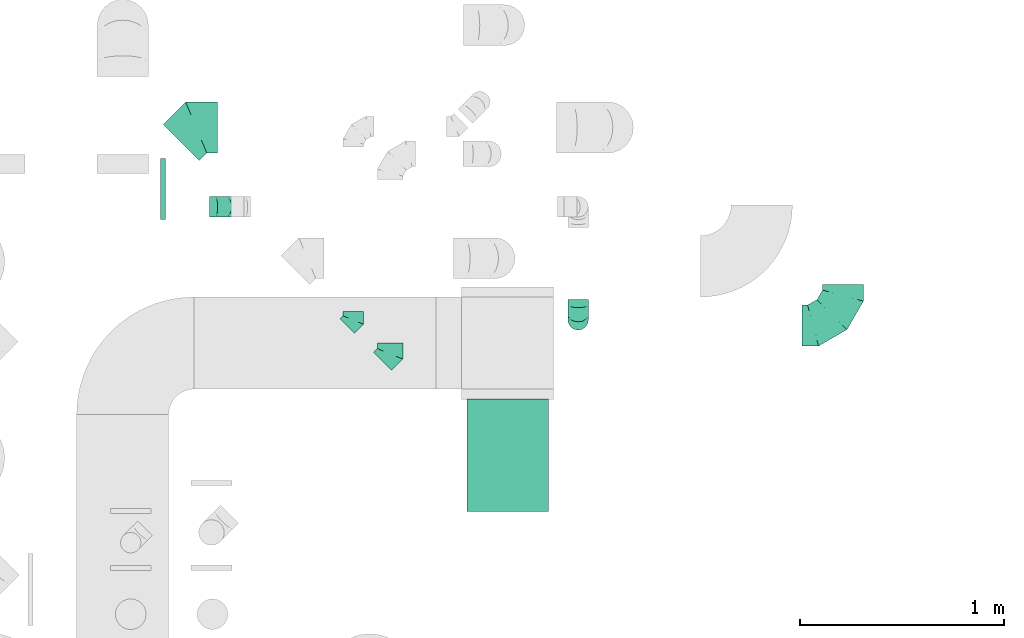
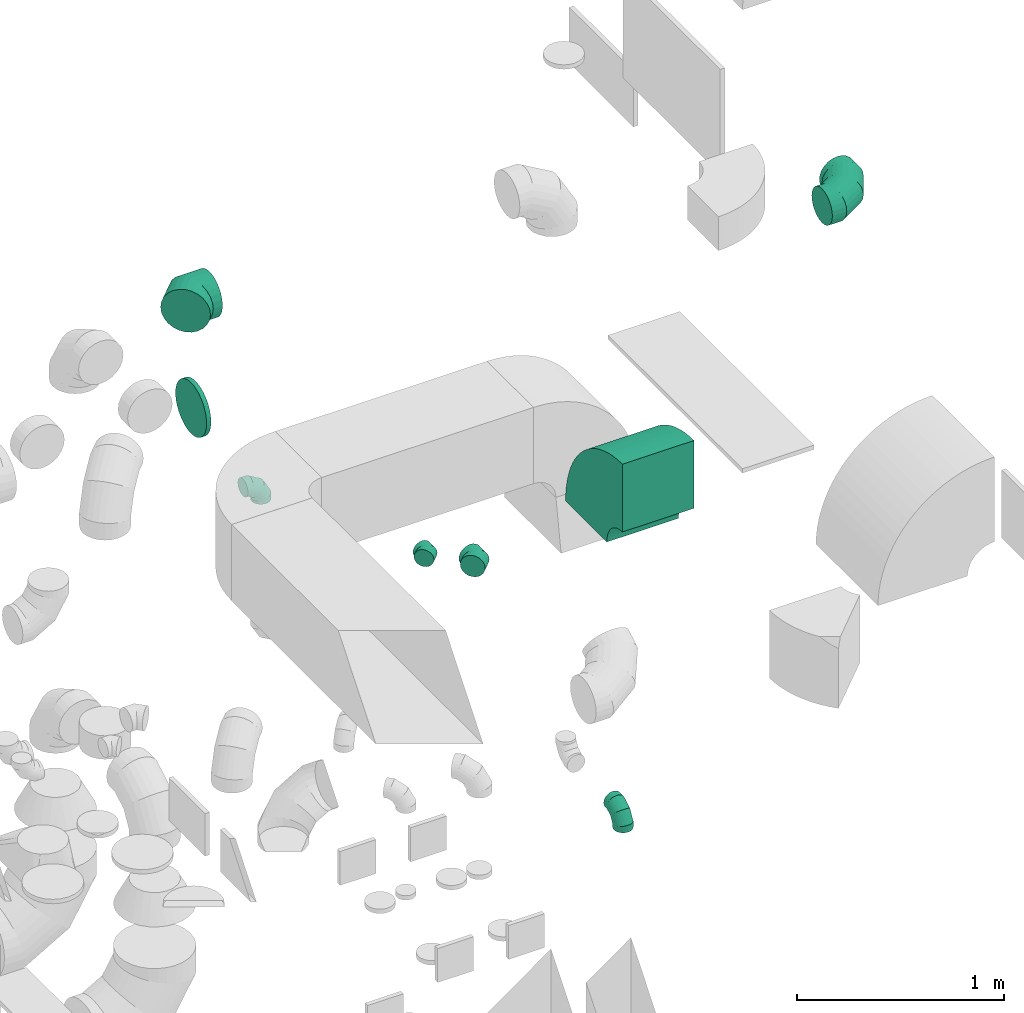
# One storey, part 37 of 59: 8 flow fittings.
"""IFC2X3 building model written with IfcOpenShell, lengths in millimetres."""

from ifc_helpers import new_model, entity, si_unit, converted_unit, derived_unit, direction, frame, frame_2d, origin, origin_2d_with_axis, place, context, subcontext, project, spatial, polyline, circle_curve, parameter, trimmed, segment, composite_curve, circle, outline, extrude, faceted_brep, source, transform, mapped, material, type_object, type_shapes, element, save


model = new_model("IFC2X3")

# Units and contexts
model_context = context("Model", 3, precision=0.01, world=origin(), true_north=direction((6.12303176911189e-17, 1.0)))
body_context = subcontext(model_context, "Body", "Model", "MODEL_VIEW")
ifc_project = project(units=[si_unit("LENGTHUNIT", "METRE", prefix="MILLI"), si_unit("AREAUNIT", "SQUARE_METRE"), si_unit("VOLUMEUNIT", "CUBIC_METRE"), converted_unit("PLANEANGLEUNIT", "DEGREE", entity("IfcRatioMeasure", 0.0174532925199433), si_unit("PLANEANGLEUNIT", "RADIAN"), dimensions=[0, 0, 0, 0, 0, 0, 0]), si_unit("MASSUNIT", "GRAM", prefix="KILO"), derived_unit("MASSDENSITYUNIT", [(si_unit("MASSUNIT", "GRAM", prefix="KILO"), 1), (si_unit("LENGTHUNIT", "METRE"), -3)]), derived_unit("MOMENTOFINERTIAUNIT", [(si_unit("LENGTHUNIT", "METRE"), 4)]), si_unit("TIMEUNIT", "SECOND"), si_unit("FREQUENCYUNIT", "HERTZ"), si_unit("THERMODYNAMICTEMPERATUREUNIT", "DEGREE_CELSIUS"), derived_unit("THERMALTRANSMITTANCEUNIT", [(si_unit("MASSUNIT", "GRAM", prefix="KILO"), 1), (si_unit("THERMODYNAMICTEMPERATUREUNIT", "KELVIN"), -1), (si_unit("TIMEUNIT", "SECOND"), -3)]), derived_unit("VOLUMETRICFLOWRATEUNIT", [(si_unit("LENGTHUNIT", "METRE"), 3), (si_unit("TIMEUNIT", "SECOND"), -1)]), derived_unit("MASSFLOWRATEUNIT", [(si_unit("MASSUNIT", "GRAM", prefix="KILO"), 1), (si_unit("TIMEUNIT", "SECOND"), -1)]), derived_unit("ROTATIONALFREQUENCYUNIT", [(si_unit("TIMEUNIT", "SECOND"), -1)]), si_unit("ELECTRICCURRENTUNIT", "AMPERE"), si_unit("ELECTRICVOLTAGEUNIT", "VOLT"), si_unit("POWERUNIT", "WATT"), si_unit("FORCEUNIT", "NEWTON", prefix="KILO"), si_unit("ILLUMINANCEUNIT", "LUX"), si_unit("LUMINOUSFLUXUNIT", "LUMEN"), si_unit("LUMINOUSINTENSITYUNIT", "CANDELA"), derived_unit("USERDEFINED", [(si_unit("MASSUNIT", "GRAM", prefix="KILO"), -1), (si_unit("LENGTHUNIT", "METRE"), -2), (si_unit("TIMEUNIT", "SECOND"), 3), (si_unit("LUMINOUSFLUXUNIT", "LUMEN"), 1)]), derived_unit("LINEARVELOCITYUNIT", [(si_unit("LENGTHUNIT", "METRE"), 1), (si_unit("TIMEUNIT", "SECOND"), -1)]), si_unit("PRESSUREUNIT", "PASCAL"), derived_unit("USERDEFINED", [(si_unit("LENGTHUNIT", "METRE"), -2), (si_unit("MASSUNIT", "GRAM", prefix="KILO"), 1), (si_unit("TIMEUNIT", "SECOND"), -2)]), derived_unit("LINEARFORCEUNIT", [(si_unit("MASSUNIT", "GRAM", prefix="KILO"), 1), (si_unit("LENGTHUNIT", "METRE"), 1), (si_unit("TIMEUNIT", "SECOND"), -2), (si_unit("LENGTHUNIT", "METRE"), -1)]), derived_unit("PLANARFORCEUNIT", [(si_unit("MASSUNIT", "GRAM", prefix="KILO"), 1), (si_unit("LENGTHUNIT", "METRE"), 1), (si_unit("TIMEUNIT", "SECOND"), -2), (si_unit("LENGTHUNIT", "METRE"), -2)])], contexts=[model_context])

# Site, building, storey
site_placement = place(None, origin())
site = spatial("IfcSite", under=ifc_project, at=site_placement, CompositionType="ELEMENT")
building_placement = place(site_placement, origin())
building = spatial("IfcBuilding", under=site, at=building_placement, CompositionType="ELEMENT")
storey_placement = place(building_placement, frame((0.0, 0.0, 28200.0)))
storey = spatial("IfcBuildingStorey", under=building, at=storey_placement, CompositionType="ELEMENT", Elevation=28200.0)

# Flow fittings
ifc_material = material()
duct_fitting_type_1 = type_object("IfcDuctFittingType", PredefinedType="NOTDEFINED", material=ifc_material)
shared_shape_1 = source(origin(), body_context, "Body", "SweptSolid", [
    extrude(circle(Radius=149.999999999999, at=origin_2d_with_axis()), frame((0.0, 0.0, 0.0), z_axis=(1.0, 0.0, 0.0), x_axis=(0.0, 1.0, 0.0)), (0.0, 0.0, 1.0), 25.0000000000018),
])
type_shapes(duct_fitting_type_1, [shared_shape_1])
flow_fitting_1_placement = place(storey_placement, frame((57282.5, 12192.32, 3100.0)))
element("IfcFlowFitting", 1, at=flow_fitting_1_placement, inside=storey, type_object=duct_fitting_type_1, material=ifc_material, context=body_context, shape_type="MappedRepresentation", body=[
    mapped(shared_shape_1, transform((0.0, 0.0, 0.0), scale=1.0)),
])
duct_fitting_type_2 = type_object("IfcDuctFittingType", PredefinedType="NOTDEFINED", material=ifc_material)
shared_shape_2 = source(origin(), body_context, "Body", "Brep", [
    faceted_brep([(-100.0, 0.0, -50.0), (-100.0, -12.94, -48.3), (-100.0, -25.0, -43.3), (-100.0, -35.36, -35.36), (-100.0, -43.3, -25.0), (-100.0, -48.3, -12.94), (-100.0, -50.0, 0.0), (-100.0, -48.3, 12.94), (-100.0, -43.3, 25.0), (-100.0, -35.36, 35.36), (-100.0, -25.0, 43.3), (-100.0, -12.94, 48.3), (-100.0, 0.0, 50.0), (-100.0, 12.94, 48.3), (-100.0, 25.0, 43.3), (-100.0, 35.36, 35.36), (-100.0, 43.3, 25.0), (-100.0, 48.3, 12.94), (-100.0, 50.0, 0.0), (-100.0, 48.3, -12.94), (-100.0, 43.3, -25.0), (-100.0, 35.36, -35.36), (-100.0, 25.0, -43.3), (-100.0, 12.94, -48.3), (-76.67, 12.94, 48.3), (-79.9, 25.0, 43.3), (-73.21, 0.0, 50.0), (-82.68, 35.36, 35.36), (-86.15, 48.3, 12.94), (-86.6, 50.0, 0.0), (-84.81, 43.3, 25.0), (-84.81, 43.3, -25.0), (-82.68, 35.36, -35.36), (-86.15, 48.3, -12.94), (-76.67, 12.94, -48.3), (-73.21, 0.0, -50.0), (-79.9, 25.0, -43.3), (-69.74, -12.94, -48.3), (-66.51, -25.0, -43.3), (-63.73, -35.36, -35.36), (-61.6, -43.3, -25.0), (-60.26, -48.3, -12.94), (-59.81, -50.0, 0.0), (-60.26, -48.3, 12.94), (-61.6, -43.3, 25.0), (-63.73, -35.36, 35.36), (-66.51, -25.0, 43.3), (-69.74, -12.94, 48.3), (-36.27, 36.27, 48.3), (-45.1, 45.1, 43.3), (-26.79, 26.79, 50.0), (-52.68, 52.68, 35.36), (-58.49, 58.49, 25.0), (-62.15, 62.15, 12.94), (-63.4, 63.4, 0.0), (-62.15, 62.15, -12.94), (-58.49, 58.49, -25.0), (-52.68, 52.68, -35.36), (-36.27, 36.27, -48.3), (-26.79, 26.79, -50.0), (-45.1, 45.1, -43.3), (-17.32, 17.32, -48.3), (-8.49, 8.49, -43.3), (-0.91, 0.91, -35.36), (4.9, -4.9, -25.0), (8.56, -8.56, -12.94), (9.81, -9.81, 0.0), (8.56, -8.56, 12.94), (4.9, -4.9, 25.0), (-0.91, 0.91, 35.36), (-8.49, 8.49, 43.3), (-17.32, 17.32, 48.3), (-12.94, 76.67, 48.3), (-25.0, 79.9, 43.3), (0.0, 73.21, 50.0), (-35.36, 82.68, 35.36), (-43.3, 84.81, 25.0), (-48.3, 86.15, 12.94), (-50.0, 86.6, 0.0), (-48.3, 86.15, -12.94), (-43.3, 84.81, -25.0), (-35.36, 82.68, -35.36), (-12.94, 76.67, -48.3), (0.0, 73.21, -50.0), (-25.0, 79.9, -43.3), (12.94, 69.74, -48.3), (25.0, 66.51, -43.3), (35.36, 63.73, -35.36), (43.3, 61.6, -25.0), (48.3, 60.26, -12.94), (50.0, 59.81, 0.0), (48.3, 60.26, 12.94), (43.3, 61.6, 25.0), (35.36, 63.73, 35.36), (25.0, 66.51, 43.3), (12.94, 69.74, 48.3), (-12.94, 100.0, -48.3), (-25.0, 100.0, -43.3), (-35.36, 100.0, -35.36), (-43.3, 100.0, -25.0), (-48.3, 100.0, -12.94), (-50.0, 100.0, 0.0), (-48.3, 100.0, 12.94), (-43.3, 100.0, 25.0), (-35.36, 100.0, 35.36), (-25.0, 100.0, 43.3), (-12.94, 100.0, 48.3), (0.0, 100.0, 50.0), (12.94, 100.0, 48.3), (25.0, 100.0, 43.3), (35.36, 100.0, 35.36), (43.3, 100.0, 25.0), (48.3, 100.0, 12.94), (50.0, 100.0, 0.0), (48.3, 100.0, -12.94), (43.3, 100.0, -25.0), (35.36, 100.0, -35.36), (25.0, 100.0, -43.3), (12.94, 100.0, -48.3), (0.0, 100.0, -50.0)], [[[0, 1, 2, 3, 4, 5, 6, 7, 8, 9, 10, 11, 12, 13, 14, 15, 16, 17, 18, 19, 20, 21, 22, 23]], [[24, 25, 14, 13]], [[26, 24, 13, 12]], [[14, 25, 27, 15]], [[28, 29, 18, 17]], [[30, 28, 17, 16]], [[15, 27, 30, 16]], [[20, 31, 32, 21]], [[33, 31, 20, 19]], [[18, 29, 33, 19]], [[34, 35, 0, 23]], [[36, 34, 23, 22]], [[32, 36, 22, 21]], [[2, 1, 37, 38]], [[3, 2, 38, 39]], [[0, 35, 37, 1]], [[5, 4, 40, 41]], [[6, 5, 41, 42]], [[3, 39, 40, 4]], [[6, 42, 43, 7]], [[7, 43, 44, 8]], [[8, 44, 45, 9]], [[10, 46, 47, 11]], [[11, 47, 26, 12]], [[10, 9, 45, 46]], [[48, 49, 25, 24]], [[50, 48, 24, 26]], [[27, 25, 49, 51]], [[52, 53, 28, 30]], [[51, 52, 30, 27]], [[29, 28, 53, 54]], [[55, 56, 31, 33]], [[54, 55, 33, 29]], [[57, 32, 31, 56]], [[58, 59, 35, 34]], [[60, 58, 34, 36]], [[57, 60, 36, 32]], [[37, 35, 59, 61]], [[38, 37, 61, 62]], [[39, 38, 62, 63]], [[41, 40, 64, 65]], [[42, 41, 65, 66]], [[63, 64, 40, 39]], [[43, 42, 66, 67]], [[44, 43, 67, 68]], [[68, 69, 45, 44]], [[46, 45, 69, 70]], [[47, 46, 70, 71]], [[26, 47, 71, 50]], [[72, 73, 49, 48]], [[74, 72, 48, 50]], [[51, 49, 73, 75]], [[76, 77, 53, 52]], [[75, 76, 52, 51]], [[54, 53, 77, 78]], [[79, 80, 56, 55]], [[78, 79, 55, 54]], [[81, 57, 56, 80]], [[82, 83, 59, 58]], [[84, 82, 58, 60]], [[81, 84, 60, 57]], [[61, 59, 83, 85]], [[62, 61, 85, 86]], [[63, 62, 86, 87]], [[65, 64, 88, 89]], [[66, 65, 89, 90]], [[87, 88, 64, 63]], [[67, 66, 90, 91]], [[68, 67, 91, 92]], [[92, 93, 69, 68]], [[70, 69, 93, 94]], [[71, 70, 94, 95]], [[50, 71, 95, 74]], [[96, 97, 98, 99, 100, 101, 102, 103, 104, 105, 106, 107, 108, 109, 110, 111, 112, 113, 114, 115, 116, 117, 118, 119]], [[72, 74, 107, 106]], [[73, 72, 106, 105]], [[75, 73, 105, 104]], [[77, 76, 103, 102]], [[78, 77, 102, 101]], [[75, 104, 103, 76]], [[78, 101, 100, 79]], [[79, 100, 99, 80]], [[80, 99, 98, 81]], [[96, 119, 83, 82]], [[97, 96, 82, 84]], [[84, 81, 98, 97]], [[83, 119, 118, 85]], [[85, 118, 117, 86]], [[86, 117, 116, 87]], [[88, 115, 114, 89]], [[89, 114, 113, 90]], [[87, 116, 115, 88]], [[91, 90, 113, 112]], [[92, 91, 112, 111]], [[93, 92, 111, 110]], [[95, 94, 109, 108]], [[74, 95, 108, 107]], [[110, 109, 94, 93]]]),
])
type_shapes(duct_fitting_type_2, [shared_shape_2])
for number, where, z_axis, x_axis in (
    (2, (57621.5, 12105.64, 2600.0), (0.0, 1.0, 0.0), (1.0, 0.0, 0.0)),
    (3, (59324.53, 11553.05, 400.0), (1.0, 0.0, 0.0), (0.0, -1.0, 0.0)),
):
    element("IfcFlowFitting", number, at=place(storey_placement, frame(where, z_axis=z_axis, x_axis=x_axis)), inside=storey, type_object=duct_fitting_type_2, material=ifc_material, context=body_context, shape_type="MappedRepresentation", body=[
        mapped(shared_shape_2, transform((0.0, 0.0, 0.0), scale=1.0)),
    ])
duct_fitting_type_3 = type_object("IfcDuctFittingType", PredefinedType="NOTDEFINED", material=ifc_material)
shared_shape_3 = source(origin(), body_context, "Body", "Brep", [
    faceted_brep([(-200.0, 0.0, -100.0), (-200.0, -25.88, -96.59), (-200.0, -50.0, -86.6), (-200.0, -70.71, -70.71), (-200.0, -86.6, -50.0), (-200.0, -96.59, -25.88), (-200.0, -100.0, 0.0), (-200.0, -96.59, 25.88), (-200.0, -86.6, 50.0), (-200.0, -70.71, 70.71), (-200.0, -50.0, 86.6), (-200.0, -25.88, 96.59), (-200.0, 0.0, 100.0), (-200.0, 25.88, 96.59), (-200.0, 50.0, 86.6), (-200.0, 70.71, 70.71), (-200.0, 86.6, 50.0), (-200.0, 96.59, 25.88), (-200.0, 100.0, 0.0), (-200.0, 96.59, -25.88), (-200.0, 86.6, -50.0), (-200.0, 70.71, -70.71), (-200.0, 50.0, -86.6), (-200.0, 25.88, -96.59), (-153.35, 25.88, 96.59), (-159.81, 50.0, 86.6), (-146.41, 0.0, 100.0), (-165.36, 70.71, 70.71), (-172.29, 96.59, 25.88), (-173.21, 100.0, 0.0), (-169.62, 86.6, 50.0), (-169.62, 86.6, -50.0), (-165.36, 70.71, -70.71), (-172.29, 96.59, -25.88), (-153.35, 25.88, -96.59), (-146.41, 0.0, -100.0), (-159.81, 50.0, -86.6), (-139.48, -25.88, -96.59), (-133.01, -50.0, -86.6), (-127.46, -70.71, -70.71), (-123.21, -86.6, -50.0), (-120.53, -96.59, -25.88), (-119.62, -100.0, 0.0), (-120.53, -96.59, 25.88), (-123.21, -86.6, 50.0), (-127.46, -70.71, 70.71), (-133.01, -50.0, 86.6), (-139.48, -25.88, 96.59), (-72.54, 72.54, 96.59), (-90.19, 90.19, 86.6), (-53.59, 53.59, 100.0), (-105.35, 105.35, 70.71), (-116.99, 116.99, 50.0), (-124.3, 124.3, 25.88), (-126.79, 126.79, 0.0), (-124.3, 124.3, -25.88), (-116.99, 116.99, -50.0), (-105.35, 105.35, -70.71), (-72.54, 72.54, -96.59), (-53.59, 53.59, -100.0), (-90.19, 90.19, -86.6), (-34.64, 34.64, -96.59), (-16.99, 16.99, -86.6), (-1.83, 1.83, -70.71), (9.81, -9.81, -50.0), (17.12, -17.12, -25.88), (19.62, -19.62, 0.0), (17.12, -17.12, 25.88), (9.81, -9.81, 50.0), (-1.83, 1.83, 70.71), (-16.99, 16.99, 86.6), (-34.64, 34.64, 96.59), (-25.88, 153.35, 96.59), (-50.0, 159.81, 86.6), (0.0, 146.41, 100.0), (-70.71, 165.36, 70.71), (-86.6, 169.62, 50.0), (-96.59, 172.29, 25.88), (-100.0, 173.21, 0.0), (-96.59, 172.29, -25.88), (-86.6, 169.62, -50.0), (-70.71, 165.36, -70.71), (-25.88, 153.35, -96.59), (0.0, 146.41, -100.0), (-50.0, 159.81, -86.6), (25.88, 139.48, -96.59), (50.0, 133.01, -86.6), (70.71, 127.46, -70.71), (86.6, 123.21, -50.0), (96.59, 120.53, -25.88), (100.0, 119.62, 0.0), (96.59, 120.53, 25.88), (86.6, 123.21, 50.0), (70.71, 127.46, 70.71), (50.0, 133.01, 86.6), (25.88, 139.48, 96.59), (-25.88, 200.0, -96.59), (-50.0, 200.0, -86.6), (-70.71, 200.0, -70.71), (-86.6, 200.0, -50.0), (-96.59, 200.0, -25.88), (-100.0, 200.0, 0.0), (-96.59, 200.0, 25.88), (-86.6, 200.0, 50.0), (-70.71, 200.0, 70.71), (-50.0, 200.0, 86.6), (-25.88, 200.0, 96.59), (0.0, 200.0, 100.0), (25.88, 200.0, 96.59), (50.0, 200.0, 86.6), (70.71, 200.0, 70.71), (86.6, 200.0, 50.0), (96.59, 200.0, 25.88), (100.0, 200.0, 0.0), (96.59, 200.0, -25.88), (86.6, 200.0, -50.0), (70.71, 200.0, -70.71), (50.0, 200.0, -86.6), (25.88, 200.0, -96.59), (0.0, 200.0, -100.0)], [[[0, 1, 2, 3, 4, 5, 6, 7, 8, 9, 10, 11, 12, 13, 14, 15, 16, 17, 18, 19, 20, 21, 22, 23]], [[24, 25, 14, 13]], [[26, 24, 13, 12]], [[14, 25, 27, 15]], [[28, 29, 18, 17]], [[30, 28, 17, 16]], [[15, 27, 30, 16]], [[20, 31, 32, 21]], [[33, 31, 20, 19]], [[18, 29, 33, 19]], [[34, 35, 0, 23]], [[36, 34, 23, 22]], [[32, 36, 22, 21]], [[1, 0, 35, 37]], [[2, 1, 37, 38]], [[38, 39, 3, 2]], [[5, 4, 40, 41]], [[6, 5, 41, 42]], [[39, 40, 4, 3]], [[6, 42, 43, 7]], [[7, 43, 44, 8]], [[8, 44, 45, 9]], [[9, 45, 46, 10]], [[10, 46, 47, 11]], [[26, 12, 11, 47]], [[48, 49, 25, 24]], [[50, 48, 24, 26]], [[27, 25, 49, 51]], [[52, 53, 28, 30]], [[51, 52, 30, 27]], [[29, 28, 53, 54]], [[55, 56, 31, 33]], [[54, 55, 33, 29]], [[32, 31, 56, 57]], [[58, 59, 35, 34]], [[60, 58, 34, 36]], [[57, 60, 36, 32]], [[37, 35, 59, 61]], [[38, 37, 61, 62]], [[39, 38, 62, 63]], [[41, 40, 64, 65]], [[42, 41, 65, 66]], [[63, 64, 40, 39]], [[43, 42, 66, 67]], [[44, 43, 67, 68]], [[68, 69, 45, 44]], [[46, 45, 69, 70]], [[47, 46, 70, 71]], [[26, 47, 71, 50]], [[72, 73, 49, 48]], [[74, 72, 48, 50]], [[51, 49, 73, 75]], [[76, 77, 53, 52]], [[75, 76, 52, 51]], [[54, 53, 77, 78]], [[79, 80, 56, 55]], [[78, 79, 55, 54]], [[57, 56, 80, 81]], [[82, 83, 59, 58]], [[84, 82, 58, 60]], [[81, 84, 60, 57]], [[61, 59, 83, 85]], [[62, 61, 85, 86]], [[63, 62, 86, 87]], [[65, 64, 88, 89]], [[66, 65, 89, 90]], [[87, 88, 64, 63]], [[67, 66, 90, 91]], [[68, 67, 91, 92]], [[92, 93, 69, 68]], [[70, 69, 93, 94]], [[71, 70, 94, 95]], [[50, 71, 95, 74]], [[96, 97, 98, 99, 100, 101, 102, 103, 104, 105, 106, 107, 108, 109, 110, 111, 112, 113, 114, 115, 116, 117, 118, 119]], [[72, 74, 107, 106]], [[73, 72, 106, 105]], [[75, 73, 105, 104]], [[102, 101, 78, 77]], [[103, 102, 77, 76]], [[75, 104, 103, 76]], [[78, 101, 100, 79]], [[79, 100, 99, 80]], [[80, 99, 98, 81]], [[84, 97, 96, 82]], [[82, 96, 119, 83]], [[84, 81, 98, 97]], [[118, 117, 86, 85]], [[119, 118, 85, 83]], [[116, 87, 86, 117]], [[88, 115, 114, 89]], [[89, 114, 113, 90]], [[115, 88, 87, 116]], [[91, 90, 113, 112]], [[92, 91, 112, 111]], [[111, 110, 93, 92]], [[95, 94, 109, 108]], [[74, 95, 108, 107]], [[110, 109, 94, 93]]]),
])
type_shapes(duct_fitting_type_3, [shared_shape_3])
flow_fitting_2_placement = place(storey_placement, frame((60620.03, 11524.89, 3600.0)))
element("IfcFlowFitting", 4, at=flow_fitting_2_placement, inside=storey, type_object=duct_fitting_type_3, material=ifc_material, context=body_context, shape_type="MappedRepresentation", body=[
    mapped(shared_shape_3, transform((0.0, 0.0, 0.0), scale=1.0)),
])
duct_fitting_type_4 = type_object("IfcDuctFittingType", PredefinedType="NOTDEFINED", material=ifc_material)
shared_shape_4 = source(origin(), body_context, "Body", "Brep", [
    faceted_brep([(-51.78, 0.0, -62.5), (-51.78, -16.18, -60.37), (-51.78, -31.25, -54.13), (-51.78, -44.19, -44.19), (-51.78, -54.13, -31.25), (-51.78, -60.37, -16.18), (-51.78, -62.5, 0.0), (-51.78, -60.37, 16.18), (-51.78, -54.13, 31.25), (-51.78, -44.19, 44.19), (-51.78, -31.25, 54.13), (-51.78, -16.18, 60.37), (-51.78, 0.0, 62.5), (-51.78, 16.18, 60.37), (-51.78, 31.25, 54.13), (-51.78, 44.19, 44.19), (-51.78, 54.13, 31.25), (-51.78, 60.37, 16.18), (-51.78, 62.5, 0.0), (-51.78, 60.37, -16.18), (-51.78, 54.13, -31.25), (-51.78, 44.19, -44.19), (-51.78, 31.25, -54.13), (-51.78, 16.18, -60.37), (-6.7, 16.18, 60.37), (-12.94, 31.25, 54.13), (0.0, 0.0, 62.5), (-18.31, 44.19, 44.19), (-22.42, 54.13, 31.25), (-25.01, 60.37, 16.18), (-25.89, 62.5, 0.0), (-25.01, 60.37, -16.18), (-22.42, 54.13, -31.25), (-18.31, 44.19, -44.19), (-6.7, 16.18, -60.37), (0.0, 0.0, -62.5), (-12.94, 31.25, -54.13), (6.7, -16.18, -60.37), (12.94, -31.25, -54.13), (18.31, -44.19, -44.19), (22.42, -54.13, -31.25), (25.01, -60.37, -16.18), (25.89, -62.5, 0.0), (25.01, -60.37, 16.18), (22.42, -54.13, 31.25), (18.31, -44.19, 44.19), (12.94, -31.25, 54.13), (6.7, -16.18, 60.37), (25.17, 48.05, 60.37), (14.51, 58.71, 54.13), (36.61, 36.61, 62.5), (5.36, 67.86, 44.19), (-1.66, 74.88, 31.25), (-6.08, 79.3, 16.18), (-7.58, 80.81, 0.0), (-6.08, 79.3, -16.18), (-1.66, 74.88, -31.25), (5.36, 67.86, -44.19), (14.51, 58.71, -54.13), (25.17, 48.05, -60.37), (36.61, 36.61, -62.5), (48.05, 25.17, -60.37), (58.71, 14.51, -54.13), (67.86, 5.36, -44.19), (74.88, -1.66, -31.25), (79.3, -6.08, -16.18), (80.81, -7.58, 0.0), (79.3, -6.08, 16.18), (74.88, -1.66, 31.25), (67.86, 5.36, 44.19), (58.71, 14.51, 54.13), (48.05, 25.17, 60.37)], [[[0, 1, 2, 3, 4, 5, 6, 7, 8, 9, 10, 11, 12, 13, 14, 15, 16, 17, 18, 19, 20, 21, 22, 23]], [[24, 25, 14, 13]], [[26, 24, 13, 12]], [[27, 15, 14, 25]], [[28, 29, 17, 16]], [[28, 16, 15, 27]], [[30, 18, 17, 29]], [[31, 32, 20, 19]], [[30, 31, 19, 18]], [[21, 20, 32, 33]], [[34, 35, 0, 23]], [[36, 34, 23, 22]], [[33, 36, 22, 21]], [[1, 0, 35, 37]], [[2, 1, 37, 38]], [[38, 39, 3, 2]], [[5, 4, 40, 41]], [[6, 5, 41, 42]], [[39, 40, 4, 3]], [[6, 42, 43, 7]], [[7, 43, 44, 8]], [[8, 44, 45, 9]], [[9, 45, 46, 10]], [[10, 46, 47, 11]], [[26, 12, 11, 47]], [[48, 49, 25, 24]], [[50, 48, 24, 26]], [[27, 25, 49, 51]], [[29, 28, 52, 53]], [[30, 29, 53, 54]], [[51, 52, 28, 27]], [[30, 54, 55, 31]], [[31, 55, 56, 32]], [[57, 33, 32, 56]], [[36, 58, 59, 34]], [[34, 59, 60, 35]], [[58, 36, 33, 57]], [[35, 60, 61, 37]], [[37, 61, 62, 38]], [[63, 39, 38, 62]], [[40, 64, 65, 41]], [[41, 65, 66, 42]], [[64, 40, 39, 63]], [[43, 42, 66, 67]], [[44, 43, 67, 68]], [[68, 69, 45, 44]], [[47, 46, 70, 71]], [[26, 47, 71, 50]], [[69, 70, 46, 45]], [[59, 58, 57, 56, 55, 54, 53, 52, 51, 49, 48, 50, 71, 70, 69, 68, 67, 66, 65, 64, 63, 62, 61, 60]]]),
])
type_shapes(duct_fitting_type_4, [shared_shape_4])
flow_fitting_3_placement = place(storey_placement, frame((58405.03, 11386.66, 2297.5), z_axis=(0.0, 0.0, 1.0), x_axis=(0.707106781186548, 0.707106781186548, 0.0)))
element("IfcFlowFitting", 5, at=flow_fitting_3_placement, inside=storey, type_object=duct_fitting_type_4, material=ifc_material, context=body_context, shape_type="MappedRepresentation", body=[
    mapped(shared_shape_4, transform((0.0, 0.0, 0.0), scale=1.0)),
])
duct_fitting_type_5 = type_object("IfcDuctFittingType", PredefinedType="NOTDEFINED", material=ifc_material)
shared_shape_5 = source(origin(), body_context, "Body", "Brep", [
    faceted_brep([(-41.42, 0.0, -50.0), (-41.42, -12.94, -48.3), (-41.42, -25.0, -43.3), (-41.42, -35.36, -35.36), (-41.42, -43.3, -25.0), (-41.42, -48.3, -12.94), (-41.42, -50.0, 0.0), (-41.42, -48.3, 12.94), (-41.42, -43.3, 25.0), (-41.42, -35.36, 35.36), (-41.42, -25.0, 43.3), (-41.42, -12.94, 48.3), (-41.42, 0.0, 50.0), (-41.42, 12.94, 48.3), (-41.42, 25.0, 43.3), (-41.42, 35.36, 35.36), (-41.42, 43.3, 25.0), (-41.42, 48.3, 12.94), (-41.42, 50.0, 0.0), (-41.42, 48.3, -12.94), (-41.42, 43.3, -25.0), (-41.42, 35.36, -35.36), (-41.42, 25.0, -43.3), (-41.42, 12.94, -48.3), (-5.36, 12.94, 48.3), (-10.36, 25.0, 43.3), (0.0, 0.0, 50.0), (-14.64, 35.36, 35.36), (-20.0, 48.3, 12.94), (-20.71, 50.0, 0.0), (-17.94, 43.3, 25.0), (-17.94, 43.3, -25.0), (-14.64, 35.36, -35.36), (-20.0, 48.3, -12.94), (-5.36, 12.94, -48.3), (0.0, 0.0, -50.0), (-10.36, 25.0, -43.3), (5.36, -12.94, -48.3), (10.36, -25.0, -43.3), (14.64, -35.36, -35.36), (17.94, -43.3, -25.0), (20.0, -48.3, -12.94), (20.71, -50.0, 0.0), (20.0, -48.3, 12.94), (17.94, -43.3, 25.0), (14.64, -35.36, 35.36), (10.36, -25.0, 43.3), (5.36, -12.94, 48.3), (29.29, 29.29, 50.0), (20.14, 38.44, 48.3), (11.61, 46.97, 43.3), (4.29, 54.29, 35.36), (-1.33, 59.91, 25.0), (-4.86, 63.44, 12.94), (-6.07, 64.64, 0.0), (-4.86, 63.44, -12.94), (-1.33, 59.91, -25.0), (4.29, 54.29, -35.36), (11.61, 46.97, -43.3), (20.14, 38.44, -48.3), (29.29, 29.29, -50.0), (38.44, 20.14, -48.3), (46.97, 11.61, -43.3), (54.29, 4.29, -35.36), (59.91, -1.33, -25.0), (63.44, -4.86, -12.94), (64.64, -6.07, 0.0), (63.44, -4.86, 12.94), (59.91, -1.33, 25.0), (54.29, 4.29, 35.36), (46.97, 11.61, 43.3), (38.44, 20.14, 48.3)], [[[0, 1, 2, 3, 4, 5, 6, 7, 8, 9, 10, 11, 12, 13, 14, 15, 16, 17, 18, 19, 20, 21, 22, 23]], [[24, 25, 14, 13]], [[26, 24, 13, 12]], [[14, 25, 27, 15]], [[28, 29, 18, 17]], [[30, 28, 17, 16]], [[16, 15, 27, 30]], [[20, 31, 32, 21]], [[33, 31, 20, 19]], [[18, 29, 33, 19]], [[34, 35, 0, 23]], [[36, 34, 23, 22]], [[32, 36, 22, 21]], [[1, 0, 35, 37]], [[2, 1, 37, 38]], [[38, 39, 3, 2]], [[5, 4, 40, 41]], [[6, 5, 41, 42]], [[39, 40, 4, 3]], [[6, 42, 43, 7]], [[7, 43, 44, 8]], [[8, 44, 45, 9]], [[9, 45, 46, 10]], [[10, 46, 47, 11]], [[26, 12, 11, 47]], [[24, 26, 48, 49]], [[25, 24, 49, 50]], [[27, 25, 50, 51]], [[28, 30, 52, 53]], [[29, 28, 53, 54]], [[27, 51, 52, 30]], [[29, 54, 55, 33]], [[33, 55, 56, 31]], [[31, 56, 57, 32]], [[36, 58, 59, 34]], [[34, 59, 60, 35]], [[36, 32, 57, 58]], [[61, 62, 38, 37]], [[60, 61, 37, 35]], [[63, 39, 38, 62]], [[40, 64, 65, 41]], [[41, 65, 66, 42]], [[64, 40, 39, 63]], [[43, 42, 66, 67]], [[44, 43, 67, 68]], [[68, 69, 45, 44]], [[47, 46, 70, 71]], [[26, 47, 71, 48]], [[69, 70, 46, 45]], [[59, 58, 57, 56, 55, 54, 53, 52, 51, 50, 49, 48, 71, 70, 69, 68, 67, 66, 65, 64, 63, 62, 61, 60]]]),
])
type_shapes(duct_fitting_type_5, [shared_shape_5])
flow_fitting_4_placement = place(storey_placement, frame((58225.44, 11551.76, 2300.0), z_axis=(0.0, 0.0, 1.0), x_axis=(0.707106781186548, 0.707106781186548, 0.0)))
element("IfcFlowFitting", 6, at=flow_fitting_4_placement, inside=storey, type_object=duct_fitting_type_5, material=ifc_material, context=body_context, shape_type="MappedRepresentation", body=[
    mapped(shared_shape_5, transform((0.0, 0.0, 0.0), scale=1.0)),
])
duct_fitting_type_6 = type_object("IfcDuctFittingType", PredefinedType="NOTDEFINED", material=ifc_material)
shared_shape_6 = source(origin(), body_context, "Body", "Brep", [
    faceted_brep([(-103.55, 0.0, -125.0), (-103.55, -32.35, -120.74), (-103.55, -62.5, -108.25), (-103.55, -88.39, -88.39), (-103.55, -108.25, -62.5), (-103.55, -120.74, -32.35), (-103.55, -125.0, 0.0), (-103.55, -120.74, 32.35), (-103.55, -108.25, 62.5), (-103.55, -88.39, 88.39), (-103.55, -62.5, 108.25), (-103.55, -32.35, 120.74), (-103.55, 0.0, 125.0), (-103.55, 32.35, 120.74), (-103.55, 62.5, 108.25), (-103.55, 88.39, 88.39), (-103.55, 108.25, 62.5), (-103.55, 120.74, 32.35), (-103.55, 125.0, 0.0), (-103.55, 120.74, -32.35), (-103.55, 108.25, -62.5), (-103.55, 88.39, -88.39), (-103.55, 62.5, -108.25), (-103.55, 32.35, -120.74), (-13.4, 32.35, 120.74), (-25.89, 62.5, 108.25), (0.0, 0.0, 125.0), (-36.61, 88.39, 88.39), (-44.84, 108.25, 62.5), (-50.01, 120.74, 32.35), (-51.78, 125.0, 0.0), (-50.01, 120.74, -32.35), (-44.84, 108.25, -62.5), (-36.61, 88.39, -88.39), (-13.4, 32.35, -120.74), (0.0, 0.0, -125.0), (-25.89, 62.5, -108.25), (13.4, -32.35, -120.74), (25.89, -62.5, -108.25), (36.61, -88.39, -88.39), (44.84, -108.25, -62.5), (50.01, -120.74, -32.35), (51.78, -125.0, 0.0), (50.01, -120.74, 32.35), (44.84, -108.25, 62.5), (36.61, -88.39, 88.39), (25.89, -62.5, 108.25), (13.4, -32.35, 120.74), (73.22, 73.22, 125.0), (50.35, 96.1, 120.74), (29.03, 117.42, 108.25), (10.72, 135.72, 88.39), (-3.32, 149.77, 62.5), (-12.15, 158.6, 32.35), (-15.17, 161.61, 0.0), (-12.15, 158.6, -32.35), (-3.32, 149.77, -62.5), (10.72, 135.72, -88.39), (29.03, 117.42, -108.25), (50.35, 96.1, -120.74), (73.22, 73.22, -125.0), (96.1, 50.35, -120.74), (117.42, 29.03, -108.25), (135.72, 10.72, -88.39), (149.77, -3.32, -62.5), (158.6, -12.15, -32.35), (161.61, -15.17, 0.0), (158.6, -12.15, 32.35), (149.77, -3.32, 62.5), (135.72, 10.72, 88.39), (117.42, 29.03, 108.25), (96.1, 50.35, 120.74)], [[[0, 1, 2, 3, 4, 5, 6, 7, 8, 9, 10, 11, 12, 13, 14, 15, 16, 17, 18, 19, 20, 21, 22, 23]], [[24, 25, 14, 13]], [[26, 24, 13, 12]], [[14, 25, 27, 15]], [[28, 29, 17, 16]], [[28, 16, 15, 27]], [[30, 18, 17, 29]], [[31, 32, 20, 19]], [[30, 31, 19, 18]], [[32, 33, 21, 20]], [[34, 35, 0, 23]], [[36, 34, 23, 22]], [[33, 36, 22, 21]], [[1, 0, 35, 37]], [[2, 1, 37, 38]], [[38, 39, 3, 2]], [[5, 4, 40, 41]], [[6, 5, 41, 42]], [[39, 40, 4, 3]], [[6, 42, 43, 7]], [[7, 43, 44, 8]], [[8, 44, 45, 9]], [[9, 45, 46, 10]], [[10, 46, 47, 11]], [[26, 12, 11, 47]], [[24, 26, 48, 49]], [[25, 24, 49, 50]], [[27, 25, 50, 51]], [[29, 28, 52, 53]], [[30, 29, 53, 54]], [[51, 52, 28, 27]], [[30, 54, 55, 31]], [[31, 55, 56, 32]], [[57, 33, 32, 56]], [[36, 58, 59, 34]], [[34, 59, 60, 35]], [[58, 36, 33, 57]], [[35, 60, 61, 37]], [[37, 61, 62, 38]], [[63, 39, 38, 62]], [[40, 64, 65, 41]], [[41, 65, 66, 42]], [[64, 40, 39, 63]], [[43, 42, 66, 67]], [[44, 43, 67, 68]], [[68, 69, 45, 44]], [[47, 46, 70, 71]], [[26, 47, 71, 48]], [[69, 70, 46, 45]], [[59, 58, 57, 56, 55, 54, 53, 52, 51, 50, 49, 48, 71, 70, 69, 68, 67, 66, 65, 64, 63, 62, 61, 60]]]),
])
type_shapes(duct_fitting_type_6, [shared_shape_6])
flow_fitting_5_placement = place(storey_placement, frame((57456.68, 12493.72, 3500.0), z_axis=(0.0, 0.0, 1.0), x_axis=(-1.0, 0.0, 0.0)))
element("IfcFlowFitting", 7, at=flow_fitting_5_placement, inside=storey, type_object=duct_fitting_type_6, material=ifc_material, context=body_context, shape_type="MappedRepresentation", body=[
    mapped(shared_shape_6, transform((0.0, 0.0, 0.0), scale=1.0)),
])
duct_fitting_type_7 = type_object("IfcDuctFittingType", PredefinedType="NOTDEFINED", material=ifc_material)
shared_shape_7 = source(origin(), body_context, "Body", "SweptSolid", [
    extrude(outline(composite_curve([segment(polyline([(-375.0, -175.0), (25.0, -175.0)]), True, "CONTINUOUS"), segment(trimmed(circle_curve(frame_2d((175.0, -175.0), x_axis=(0.0, 1.0)), 150.0), [parameter(0.0)], [parameter(90.0)], True, "PARAMETER"), False, "CONTINUOUS"), segment(polyline([(175.0, -25.0), (175.0, 375.0)]), True, "CONTINUOUS"), segment(trimmed(circle_curve(frame_2d((175.0, -175.0), x_axis=(0.0, 1.0)), 550.0), [parameter(0.0)], [parameter(90.0)], True, "PARAMETER"), True, "CONTINUOUS")], self_intersect=False)), frame((-175.0, 175.0, -200.0), z_axis=(0.0, 0.0, 1.0), x_axis=(-1.0, 0.0, 0.0)), (0.0, 0.0, 1.0), 400.0),
])
type_shapes(duct_fitting_type_7, [shared_shape_7])
flow_fitting_6_placement = place(storey_placement, frame((58980.38, 10965.63, 3000.0), z_axis=(-1.0, 0.0, 5.63309945549943e-07), x_axis=(0.0, 1.0, 0.0)))
element("IfcFlowFitting", 8, at=flow_fitting_6_placement, inside=storey, type_object=duct_fitting_type_7, material=ifc_material, context=body_context, shape_type="MappedRepresentation", body=[
    mapped(shared_shape_7, transform((0.0, 0.0, 0.0), scale=1.0)),
])

save(model, "model.ifc")
